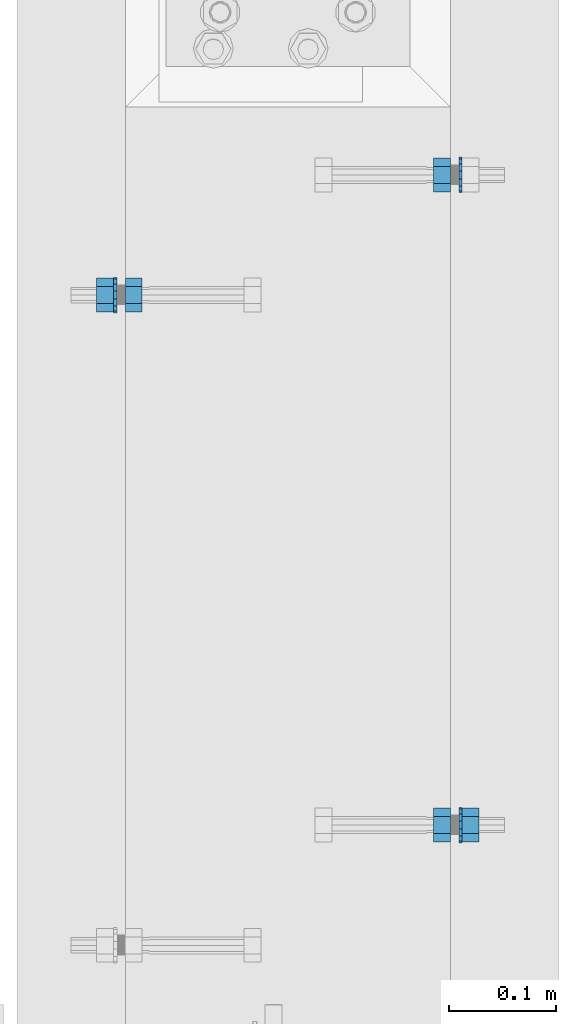
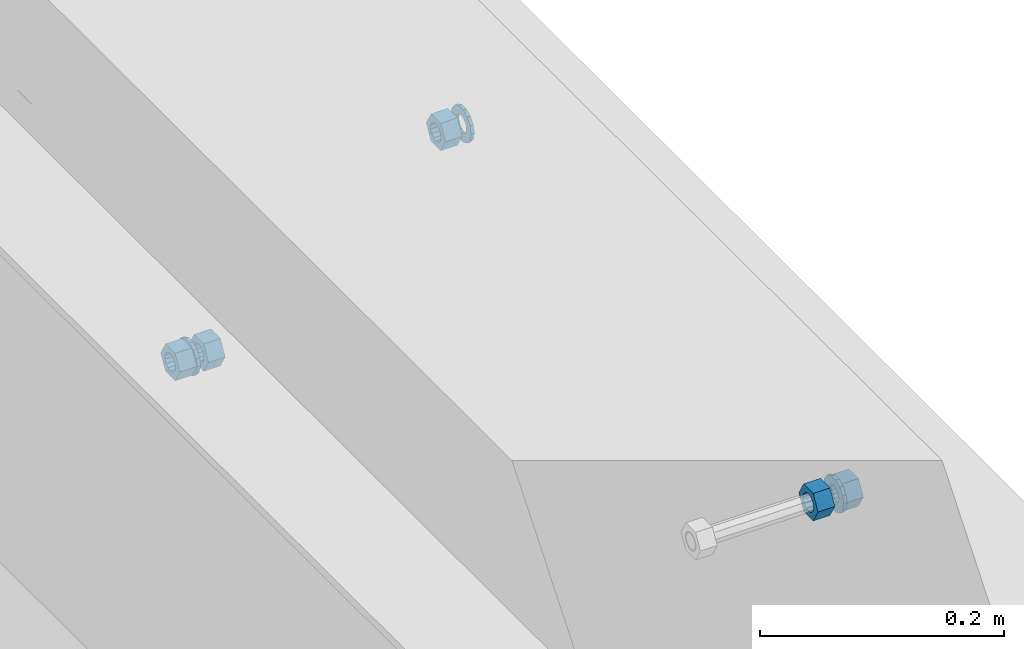
# One storey, part 548 of 975: 8 beams.
"""IFC2X3 building model written with IfcOpenShell, lengths in millimetres."""

from ifc_helpers import new_model, si_unit, frame, origin_with_axes, place, context, subcontext, project, spatial, faceted_brep, material, type_object, element, save


model = new_model("IFC2X3")

# Units and contexts
model_context = context("Model", 3, precision=1e-05, world=origin_with_axes())
body_context = subcontext(model_context, "Body", "Model", "MODEL_VIEW")
ifc_project = project(units=[si_unit("LENGTHUNIT", "METRE", prefix="MILLI"), si_unit("AREAUNIT", "SQUARE_METRE"), si_unit("VOLUMEUNIT", "CUBIC_METRE"), si_unit("MASSUNIT", "GRAM", prefix="KILO"), si_unit("TIMEUNIT", "SECOND"), si_unit("PLANEANGLEUNIT", "RADIAN"), si_unit("SOLIDANGLEUNIT", "STERADIAN"), si_unit("THERMODYNAMICTEMPERATUREUNIT", "DEGREE_CELSIUS"), si_unit("LUMINOUSINTENSITYUNIT", "LUMEN")], contexts=[model_context])

# Site, building, storey
site_placement = place(None, origin_with_axes())
site = spatial("IfcSite", under=ifc_project, at=site_placement, CompositionType="ELEMENT")
building_placement = place(site_placement, origin_with_axes())
building = spatial("IfcBuilding", under=site, at=building_placement, Name="Undefined", CompositionType="ELEMENT")
storey_placement = place(building_placement, origin_with_axes())
storey = spatial("IfcBuildingStorey", under=building, at=storey_placement, Name="Undefined", CompositionType="ELEMENT", Elevation=0.0)

# Beams
ifc_material = material(Name="STEEL/A36")
beam_type_1 = type_object("IfcBeamType", Name="5/8_HEAVY_HEX_NUT", PredefinedType="NOTDEFINED")
beam_1_placement = place(storey_placement, frame((2016.12497640005, 6748.46242676667, 3835.4), z_axis=(0.0, 0.0, 1.0), x_axis=(1.0, 0.0, 0.0)))
element("IfcBeam", 1, at=beam_1_placement, inside=storey, type_object=beam_type_1, material=ifc_material, Name="NUT", ObjectType="5/8_HEAVY_HEX_NUT", context=body_context, shape_type="Brep", body=[
    faceted_brep([(-1.09139364212751e-11, -15.8800001144436, -2.72848410531878e-12), (1.45519152283669e-11, -7.94000005722046, -13.7500000000036), (15.8750000000146, -7.94000005722137, -13.7500000000045), (15.8749999999891, -15.8800001144446, -2.72848410531878e-12), (2.91038304567337e-11, 7.94000005722319, -13.7500000000027), (15.8750000000291, 7.94000005722319, -13.7500000000027), (2.18278728425503e-11, 15.8800001144436, 9.09494701772928e-13), (15.8750000000218, 15.8800001144427, 9.09494701772928e-13), (-7.27595761418343e-12, 7.94000005722046, 13.7500000000027), (15.8749999999927, 7.94000005722046, 13.7500000000027), (-2.18278728425503e-11, -7.94000005722228, 13.7500000000009), (15.8749999999782, -7.94000005722319, 13.7500000000009), (-7.27595761418343e-12, 0.0, 8.72999954223724), (0.0, 3.78780484388062, 7.86545780435881), (15.875, 3.78780484387971, 7.86545780435881), (15.8749999999927, -9.09494701772928e-13, 8.72999954223724), (7.27595761418343e-12, 6.82538848405238, 5.44306568481716), (15.8750000000073, 6.82538848405238, 5.44306568481716), (1.09139364212751e-11, 8.51112022706275, 1.94260765157742), (15.8750000000109, 8.51112022706093, 1.94260765157651), (1.45519152283669e-11, 8.51112022706184, -1.94260765157651), (15.8750000000146, 8.51112022706184, -1.94260765157651), (2.18278728425503e-11, 6.8253884840542, -5.44306568481716), (15.8750000000218, 6.82538848405238, -5.44306568481716), (1.81898940354586e-11, 3.78780484388153, -7.86545780435881), (15.8750000000182, 3.78780484388062, -7.86545780435881), (1.81898940354586e-11, 9.09494701772928e-13, -8.72999954223997), (15.8750000000182, 9.09494701772928e-13, -8.72999954223997), (1.09139364212751e-11, -3.78780484387971, -7.86545780436063), (15.8750000000109, -3.78780484388062, -7.86545780436063), (3.63797880709171e-12, -6.82538848405238, -5.44306568481807), (15.8750000000036, -6.82538848405329, -5.44306568481807), (0.0, -8.51112022706184, -1.94260765157833), (15.875, -8.51112022706184, -1.94260765157833), (-7.27595761418343e-12, -8.51112022706184, 1.9426076515756), (15.8749999999927, -8.51112022706275, 1.9426076515756), (-1.09139364212751e-11, -6.82538848405329, 5.44306568481534), (15.8749999999927, -6.8253884840542, 5.44306568481534), (-7.27595761418343e-12, -3.78780484388062, 7.8654578043579), (15.8749999999927, -3.78780484388153, 7.8654578043579)], [[[0, 1, 2, 3]], [[1, 4, 5, 2]], [[4, 6, 7, 5]], [[6, 8, 9, 7]], [[8, 10, 11, 9]], [[10, 0, 3, 11]], [[12, 13, 14, 15]], [[13, 16, 17, 14]], [[16, 18, 19, 17]], [[18, 20, 21, 19]], [[20, 22, 23, 21]], [[22, 24, 25, 23]], [[24, 26, 27, 25]], [[26, 28, 29, 27]], [[28, 30, 31, 29]], [[30, 32, 33, 31]], [[32, 34, 35, 33]], [[34, 36, 37, 35]], [[36, 38, 39, 37]], [[38, 12, 15, 39]], [[5, 7, 9, 11, 3, 2], [17, 19, 21, 23, 25, 27, 29, 31, 33, 35, 37, 39, 15, 14]], [[10, 8, 6, 4, 1, 0], [38, 36, 34, 32, 30, 28, 26, 24, 22, 20, 18, 16, 13, 12]]]),
])
beam_2_placement = place(storey_placement, frame((2320.92506496676, 6861.17497611239, 3886.2), z_axis=(0.0, 0.0, -1.0), x_axis=(-0.999999999999998, 6.90000001668524e-08, 0.0)))
element("IfcBeam", 2, at=beam_2_placement, inside=storey, type_object=beam_type_1, material=ifc_material, Name="NUT", ObjectType="5/8_HEAVY_HEX_NUT", context=body_context, shape_type="Brep", body=[
    faceted_brep([(-1.09139364212751e-11, -15.8800001144436, -2.72848410531878e-12), (1.45519152283669e-11, -7.94000005722046, -13.7500000000036), (15.8750000000146, -7.94000005722137, -13.7500000000045), (15.8749999999891, -15.8800001144446, -2.72848410531878e-12), (2.91038304567337e-11, 7.94000005722319, -13.7500000000027), (15.8750000000291, 7.94000005722319, -13.7500000000027), (2.18278728425503e-11, 15.8800001144436, 9.09494701772928e-13), (15.8750000000218, 15.8800001144427, 9.09494701772928e-13), (-7.27595761418343e-12, 7.94000005722046, 13.7500000000027), (15.8749999999927, 7.94000005722046, 13.7500000000027), (-2.18278728425503e-11, -7.94000005722228, 13.7500000000009), (15.8749999999782, -7.94000005722319, 13.7500000000009), (-7.27595761418343e-12, 0.0, 8.72999954223724), (0.0, 3.78780484388062, 7.86545780435881), (15.875, 3.78780484387971, 7.86545780435881), (15.8749999999927, -9.09494701772928e-13, 8.72999954223724), (7.27595761418343e-12, 6.82538848405238, 5.44306568481716), (15.8750000000073, 6.82538848405238, 5.44306568481716), (1.09139364212751e-11, 8.51112022706275, 1.94260765157742), (15.8750000000109, 8.51112022706093, 1.94260765157651), (1.45519152283669e-11, 8.51112022706184, -1.94260765157651), (15.8750000000146, 8.51112022706184, -1.94260765157651), (2.18278728425503e-11, 6.8253884840542, -5.44306568481716), (15.8750000000218, 6.82538848405238, -5.44306568481716), (1.81898940354586e-11, 3.78780484388153, -7.86545780435881), (15.8750000000182, 3.78780484388062, -7.86545780435881), (1.81898940354586e-11, 9.09494701772928e-13, -8.72999954223997), (15.8750000000182, 9.09494701772928e-13, -8.72999954223997), (1.09139364212751e-11, -3.78780484387971, -7.86545780436063), (15.8750000000109, -3.78780484388062, -7.86545780436063), (3.63797880709171e-12, -6.82538848405238, -5.44306568481807), (15.8750000000036, -6.82538848405329, -5.44306568481807), (0.0, -8.51112022706184, -1.94260765157833), (15.875, -8.51112022706184, -1.94260765157833), (-7.27595761418343e-12, -8.51112022706184, 1.9426076515756), (15.8749999999927, -8.51112022706275, 1.9426076515756), (-1.09139364212751e-11, -6.82538848405329, 5.44306568481534), (15.8749999999927, -6.8253884840542, 5.44306568481534), (-7.27595761418343e-12, -3.78780484388062, 7.8654578043579), (15.8749999999927, -3.78780484388153, 7.8654578043579)], [[[0, 1, 2, 3]], [[1, 4, 5, 2]], [[4, 6, 7, 5]], [[6, 8, 9, 7]], [[8, 10, 11, 9]], [[10, 0, 3, 11]], [[12, 13, 14, 15]], [[13, 16, 17, 14]], [[16, 18, 19, 17]], [[18, 20, 21, 19]], [[20, 22, 23, 21]], [[22, 24, 25, 23]], [[24, 26, 27, 25]], [[26, 28, 29, 27]], [[28, 30, 31, 29]], [[30, 32, 33, 31]], [[32, 34, 35, 33]], [[34, 36, 37, 35]], [[36, 38, 39, 37]], [[38, 12, 15, 39]], [[5, 7, 9, 11, 3, 2], [17, 19, 21, 23, 25, 27, 29, 31, 33, 35, 37, 39, 15, 14]], [[10, 8, 6, 4, 1, 0], [38, 36, 34, 32, 30, 28, 26, 24, 22, 20, 18, 16, 13, 12]]]),
])
beam_3_placement = place(storey_placement, frame((2320.92502900036, 6251.5749761124, 3886.2), z_axis=(0.0, 0.0, -1.0), x_axis=(-0.999999999999998, 6.90000001668524e-08, 0.0)))
element("IfcBeam", 3, at=beam_3_placement, inside=storey, type_object=beam_type_1, material=ifc_material, Name="NUT", ObjectType="5/8_HEAVY_HEX_NUT", context=body_context, shape_type="Brep", body=[
    faceted_brep([(-1.09139364212751e-11, -15.8800001144436, -2.72848410531878e-12), (1.45519152283669e-11, -7.94000005722046, -13.7500000000036), (15.8750000000146, -7.94000005722137, -13.7500000000045), (15.8749999999891, -15.8800001144446, -2.72848410531878e-12), (2.91038304567337e-11, 7.94000005722319, -13.7500000000027), (15.8750000000291, 7.94000005722319, -13.7500000000027), (2.18278728425503e-11, 15.8800001144436, 9.09494701772928e-13), (15.8750000000218, 15.8800001144427, 9.09494701772928e-13), (-7.27595761418343e-12, 7.94000005722046, 13.7500000000027), (15.8749999999927, 7.94000005722046, 13.7500000000027), (-2.18278728425503e-11, -7.94000005722228, 13.7500000000009), (15.8749999999782, -7.94000005722319, 13.7500000000009), (-7.27595761418343e-12, 0.0, 8.72999954223724), (0.0, 3.78780484388062, 7.86545780435881), (15.875, 3.78780484387971, 7.86545780435881), (15.8749999999927, -9.09494701772928e-13, 8.72999954223724), (7.27595761418343e-12, 6.82538848405238, 5.44306568481716), (15.8750000000073, 6.82538848405238, 5.44306568481716), (1.09139364212751e-11, 8.51112022706275, 1.94260765157742), (15.8750000000109, 8.51112022706093, 1.94260765157651), (1.45519152283669e-11, 8.51112022706184, -1.94260765157651), (15.8750000000146, 8.51112022706184, -1.94260765157651), (2.18278728425503e-11, 6.8253884840542, -5.44306568481716), (15.8750000000218, 6.82538848405238, -5.44306568481716), (1.81898940354586e-11, 3.78780484388153, -7.86545780435881), (15.8750000000182, 3.78780484388062, -7.86545780435881), (1.81898940354586e-11, 9.09494701772928e-13, -8.72999954223997), (15.8750000000182, 9.09494701772928e-13, -8.72999954223997), (1.09139364212751e-11, -3.78780484387971, -7.86545780436063), (15.8750000000109, -3.78780484388062, -7.86545780436063), (3.63797880709171e-12, -6.82538848405238, -5.44306568481807), (15.8750000000036, -6.82538848405329, -5.44306568481807), (0.0, -8.51112022706184, -1.94260765157833), (15.875, -8.51112022706184, -1.94260765157833), (-7.27595761418343e-12, -8.51112022706184, 1.9426076515756), (15.8749999999927, -8.51112022706275, 1.9426076515756), (-1.09139364212751e-11, -6.82538848405329, 5.44306568481534), (15.8749999999927, -6.8253884840542, 5.44306568481534), (-7.27595761418343e-12, -3.78780484388062, 7.8654578043579), (15.8749999999927, -3.78780484388153, 7.8654578043579)], [[[0, 1, 2, 3]], [[1, 4, 5, 2]], [[4, 6, 7, 5]], [[6, 8, 9, 7]], [[8, 10, 11, 9]], [[10, 0, 3, 11]], [[12, 13, 14, 15]], [[13, 16, 17, 14]], [[16, 18, 19, 17]], [[18, 20, 21, 19]], [[20, 22, 23, 21]], [[22, 24, 25, 23]], [[24, 26, 27, 25]], [[26, 28, 29, 27]], [[28, 30, 31, 29]], [[30, 32, 33, 31]], [[32, 34, 35, 33]], [[34, 36, 37, 35]], [[36, 38, 39, 37]], [[38, 12, 15, 39]], [[5, 7, 9, 11, 3, 2], [17, 19, 21, 23, 25, 27, 29, 31, 33, 35, 37, 39, 15, 14]], [[10, 8, 6, 4, 1, 0], [38, 36, 34, 32, 30, 28, 26, 24, 22, 20, 18, 16, 13, 12]]]),
])
beam_4_placement = place(storey_placement, frame((1989.13747520503, 6748.46242695565, 3835.4), z_axis=(0.0, 0.0, 1.0), x_axis=(1.0, 0.0, 0.0)))
element("IfcBeam", 4, at=beam_4_placement, inside=storey, type_object=beam_type_1, material=ifc_material, Name="NUT", ObjectType="5/8_HEAVY_HEX_NUT", context=body_context, shape_type="Brep", body=[
    faceted_brep([(-1.09139364212751e-11, -15.8800001144436, -2.72848410531878e-12), (1.45519152283669e-11, -7.94000005722046, -13.7500000000036), (15.8750000000146, -7.94000005722137, -13.7500000000045), (15.8749999999891, -15.8800001144446, -2.72848410531878e-12), (2.91038304567337e-11, 7.94000005722319, -13.7500000000027), (15.8750000000291, 7.94000005722319, -13.7500000000027), (2.18278728425503e-11, 15.8800001144436, 9.09494701772928e-13), (15.8750000000218, 15.8800001144427, 9.09494701772928e-13), (-7.27595761418343e-12, 7.94000005722046, 13.7500000000027), (15.8749999999927, 7.94000005722046, 13.7500000000027), (-2.18278728425503e-11, -7.94000005722228, 13.7500000000009), (15.8749999999782, -7.94000005722319, 13.7500000000009), (-7.27595761418343e-12, 0.0, 8.72999954223724), (0.0, 3.78780484388062, 7.86545780435881), (15.875, 3.78780484387971, 7.86545780435881), (15.8749999999927, -9.09494701772928e-13, 8.72999954223724), (7.27595761418343e-12, 6.82538848405238, 5.44306568481716), (15.8750000000073, 6.82538848405238, 5.44306568481716), (1.09139364212751e-11, 8.51112022706275, 1.94260765157742), (15.8750000000109, 8.51112022706093, 1.94260765157651), (1.45519152283669e-11, 8.51112022706184, -1.94260765157651), (15.8750000000146, 8.51112022706184, -1.94260765157651), (2.18278728425503e-11, 6.8253884840542, -5.44306568481716), (15.8750000000218, 6.82538848405238, -5.44306568481716), (1.81898940354586e-11, 3.78780484388153, -7.86545780435881), (15.8750000000182, 3.78780484388062, -7.86545780435881), (1.81898940354586e-11, 9.09494701772928e-13, -8.72999954223997), (15.8750000000182, 9.09494701772928e-13, -8.72999954223997), (1.09139364212751e-11, -3.78780484387971, -7.86545780436063), (15.8750000000109, -3.78780484388062, -7.86545780436063), (3.63797880709171e-12, -6.82538848405238, -5.44306568481807), (15.8750000000036, -6.82538848405329, -5.44306568481807), (0.0, -8.51112022706184, -1.94260765157833), (15.875, -8.51112022706184, -1.94260765157833), (-7.27595761418343e-12, -8.51112022706184, 1.9426076515756), (15.8749999999927, -8.51112022706275, 1.9426076515756), (-1.09139364212751e-11, -6.82538848405329, 5.44306568481534), (15.8749999999927, -6.8253884840542, 5.44306568481534), (-7.27595761418343e-12, -3.78780484388062, 7.8654578043579), (15.8749999999927, -3.78780484388153, 7.8654578043579)], [[[0, 1, 2, 3]], [[1, 4, 5, 2]], [[4, 6, 7, 5]], [[6, 8, 9, 7]], [[8, 10, 11, 9]], [[10, 0, 3, 11]], [[12, 13, 14, 15]], [[13, 16, 17, 14]], [[16, 18, 19, 17]], [[18, 20, 21, 19]], [[20, 22, 23, 21]], [[22, 24, 25, 23]], [[24, 26, 27, 25]], [[26, 28, 29, 27]], [[28, 30, 31, 29]], [[30, 32, 33, 31]], [[32, 34, 35, 33]], [[34, 36, 37, 35]], [[36, 38, 39, 37]], [[38, 12, 15, 39]], [[5, 7, 9, 11, 3, 2], [17, 19, 21, 23, 25, 27, 29, 31, 33, 35, 37, 39, 15, 14]], [[10, 8, 6, 4, 1, 0], [38, 36, 34, 32, 30, 28, 26, 24, 22, 20, 18, 16, 13, 12]]]),
])
beam_5_placement = place(storey_placement, frame((2347.91252900035, 6251.5749761124, 3886.2), z_axis=(0.0, 0.0, -1.0), x_axis=(-0.999999999999998, 6.90000001668524e-08, 0.0)))
element("IfcBeam", 5, at=beam_5_placement, inside=storey, type_object=beam_type_1, material=ifc_material, Name="NUT", ObjectType="5/8_HEAVY_HEX_NUT", context=body_context, shape_type="Brep", body=[
    faceted_brep([(-1.09139364212751e-11, -15.8800001144436, -2.72848410531878e-12), (1.45519152283669e-11, -7.94000005722046, -13.7500000000036), (15.8750000000146, -7.94000005722137, -13.7500000000045), (15.8749999999891, -15.8800001144446, -2.72848410531878e-12), (2.91038304567337e-11, 7.94000005722319, -13.7500000000027), (15.8750000000291, 7.94000005722319, -13.7500000000027), (2.18278728425503e-11, 15.8800001144436, 9.09494701772928e-13), (15.8750000000218, 15.8800001144427, 9.09494701772928e-13), (-7.27595761418343e-12, 7.94000005722046, 13.7500000000027), (15.8749999999927, 7.94000005722046, 13.7500000000027), (-2.18278728425503e-11, -7.94000005722228, 13.7500000000009), (15.8749999999782, -7.94000005722319, 13.7500000000009), (-7.27595761418343e-12, 0.0, 8.72999954223724), (0.0, 3.78780484388062, 7.86545780435881), (15.875, 3.78780484387971, 7.86545780435881), (15.8749999999927, -9.09494701772928e-13, 8.72999954223724), (7.27595761418343e-12, 6.82538848405238, 5.44306568481716), (15.8750000000073, 6.82538848405238, 5.44306568481716), (1.09139364212751e-11, 8.51112022706275, 1.94260765157742), (15.8750000000109, 8.51112022706093, 1.94260765157651), (1.45519152283669e-11, 8.51112022706184, -1.94260765157651), (15.8750000000146, 8.51112022706184, -1.94260765157651), (2.18278728425503e-11, 6.8253884840542, -5.44306568481716), (15.8750000000218, 6.82538848405238, -5.44306568481716), (1.81898940354586e-11, 3.78780484388153, -7.86545780435881), (15.8750000000182, 3.78780484388062, -7.86545780435881), (1.81898940354586e-11, 9.09494701772928e-13, -8.72999954223997), (15.8750000000182, 9.09494701772928e-13, -8.72999954223997), (1.09139364212751e-11, -3.78780484387971, -7.86545780436063), (15.8750000000109, -3.78780484388062, -7.86545780436063), (3.63797880709171e-12, -6.82538848405238, -5.44306568481807), (15.8750000000036, -6.82538848405329, -5.44306568481807), (0.0, -8.51112022706184, -1.94260765157833), (15.875, -8.51112022706184, -1.94260765157833), (-7.27595761418343e-12, -8.51112022706184, 1.9426076515756), (15.8749999999927, -8.51112022706275, 1.9426076515756), (-1.09139364212751e-11, -6.82538848405329, 5.44306568481534), (15.8749999999927, -6.8253884840542, 5.44306568481534), (-7.27595761418343e-12, -3.78780484388062, 7.8654578043579), (15.8749999999927, -3.78780484388153, 7.8654578043579)], [[[0, 1, 2, 3]], [[1, 4, 5, 2]], [[4, 6, 7, 5]], [[6, 8, 9, 7]], [[8, 10, 11, 9]], [[10, 0, 3, 11]], [[12, 13, 14, 15]], [[13, 16, 17, 14]], [[16, 18, 19, 17]], [[18, 20, 21, 19]], [[20, 22, 23, 21]], [[22, 24, 25, 23]], [[24, 26, 27, 25]], [[26, 28, 29, 27]], [[28, 30, 31, 29]], [[30, 32, 33, 31]], [[32, 34, 35, 33]], [[34, 36, 37, 35]], [[36, 38, 39, 37]], [[38, 12, 15, 39]], [[5, 7, 9, 11, 3, 2], [17, 19, 21, 23, 25, 27, 29, 31, 33, 35, 37, 39, 15, 14]], [[10, 8, 6, 4, 1, 0], [38, 36, 34, 32, 30, 28, 26, 24, 22, 20, 18, 16, 13, 12]]]),
])
beam_type_2 = type_object("IfcBeamType", Name="5/8_WASHER", PredefinedType="NOTDEFINED")
beam_6_placement = place(storey_placement, frame((2005.01247520503, 6748.46242684456, 3835.4), z_axis=(0.0, 0.0, 1.0), x_axis=(1.0, 0.0, 0.0)))
element("IfcBeam", 6, at=beam_6_placement, inside=storey, type_object=beam_type_2, material=ifc_material, Name="WASHER", ObjectType="5/8_WASHER", context=body_context, shape_type="Brep", body=[
    faceted_brep([(1.09139364212751e-11, -16.670000076293, -2.72848410531878e-12), (2.18278728425503e-11, -15.0191510966704, -7.23284196419536), (3.1750000000211, -15.0191510966711, -7.23284196419627), (3.17500000001019, -16.6700000762937, -1.81898940354586e-12), (2.91038304567337e-11, -10.3935750445523, -13.0331308723944), (3.17500000002838, -10.3935750445526, -13.0331308723953), (2.91038304567337e-11, -3.70942398602756, -16.2520483704566), (3.17500000002838, -3.70942398602779, -16.2520483704566), (2.5465851649642e-11, 3.70942398602961, -16.2520483704557), (3.17500000002474, 3.70942398602961, -16.2520483704566), (1.45519152283669e-11, 10.3935750445542, -13.0331308723935), (3.17500000001382, 10.3935750445537, -13.0331308723944), (0.0, 15.0191510966717, -7.23284196419354), (3.17499999999927, 15.0191510966713, -7.23284196419354), (-7.27595761418343e-12, 16.6700000762933, 0.0), (3.174999999992, 16.6700000762928, -9.09494701772928e-13), (-1.81898940354586e-11, 15.0191510966706, 7.23284196419354), (3.17499999998108, 15.0191510966704, 7.23284196419354), (-2.5465851649642e-11, 10.3935750445519, 13.0331308723926), (3.17499999997381, 10.3935750445517, 13.0331308723926), (-2.5465851649642e-11, 3.70942398602733, 16.2520483704538), (3.17499999997381, 3.7094239860271, 16.2520483704529), (-2.18278728425503e-11, -3.70942398602983, 16.2520483704529), (3.17499999997744, -3.70942398603006, 16.2520483704538), (-1.09139364212751e-11, -10.3935750445542, 13.0331308723908), (3.17499999998836, -10.3935750445544, 13.0331308723908), (0.0, -15.0191510966717, 7.23284196419172), (3.17499999999927, -15.019151096672, 7.23284196419081), (-7.27595761418343e-12, 0.0, 8.72999954223724), (0.0, 3.78780484388062, 7.86545780435881), (3.17499999998472, 3.78780484387903, 7.86545780435699), (3.17499999998836, -9.09494701772928e-13, 8.72999954223542), (7.27595761418343e-12, 6.82538848405238, 5.44306568481716), (3.17499999998836, 6.82538848405102, 5.44306568481534), (1.09139364212751e-11, 8.51112022706275, 1.94260765157742), (3.174999999992, 8.51112022705979, 1.94260765157651), (1.45519152283669e-11, 8.51112022706184, -1.94260765157651), (3.17499999999563, 8.51112022706025, -1.94260765157742), (2.18278728425503e-11, 6.8253884840542, -5.44306568481716), (3.17500000000655, 6.8253884840517, -5.44306568481807), (1.81898940354586e-11, 3.78780484388153, -7.86545780435881), (3.17500000001019, 3.78780484388017, -7.86545780435972), (1.81898940354586e-11, 9.09494701772928e-13, -8.72999954223997), (3.17500000001382, 6.82121026329696e-13, -8.72999954223997), (1.09139364212751e-11, -3.78780484387971, -7.86545780436063), (3.17500000001382, -3.78780484387994, -7.86545780436063), (3.63797880709171e-12, -6.82538848405238, -5.44306568481807), (3.17500000001019, -6.82538848405147, -5.44306568481898), (0.0, -8.51112022706184, -1.94260765157833), (3.17500000001019, -8.5111202270607, -1.94260765157924), (-7.27595761418343e-12, -8.51112022706184, 1.9426076515756), (3.17500000000291, -8.51112022706093, 1.94260765157469), (-1.09139364212751e-11, -6.82538848405329, 5.44306568481534), (3.17499999999563, -6.82538848405238, 5.44306568481534), (-7.27595761418343e-12, -3.78780484388062, 7.8654578043579), (3.174999999992, -3.78780484388085, 7.86545780435699)], [[[0, 1, 2, 3]], [[1, 4, 5, 2]], [[4, 6, 7, 5]], [[6, 8, 9, 7]], [[8, 10, 11, 9]], [[10, 12, 13, 11]], [[12, 14, 15, 13]], [[14, 16, 17, 15]], [[16, 18, 19, 17]], [[18, 20, 21, 19]], [[20, 22, 23, 21]], [[22, 24, 25, 23]], [[24, 26, 27, 25]], [[26, 0, 3, 27]], [[28, 29, 30, 31]], [[29, 32, 33, 30]], [[32, 34, 35, 33]], [[34, 36, 37, 35]], [[36, 38, 39, 37]], [[38, 40, 41, 39]], [[40, 42, 43, 41]], [[42, 44, 45, 43]], [[44, 46, 47, 45]], [[46, 48, 49, 47]], [[48, 50, 51, 49]], [[50, 52, 53, 51]], [[52, 54, 55, 53]], [[54, 28, 31, 55]], [[5, 7, 9, 11, 13, 15, 17, 19, 21, 23, 25, 27, 3, 2], [33, 35, 37, 39, 41, 43, 45, 47, 49, 51, 53, 55, 31, 30]], [[26, 24, 22, 20, 18, 16, 14, 12, 10, 8, 6, 4, 1, 0], [54, 52, 50, 48, 46, 44, 42, 40, 38, 36, 34, 32, 29, 28]]]),
])
beam_7_placement = place(storey_placement, frame((2332.03752900035, 6251.5749761124, 3886.2), z_axis=(0.0, 0.0, -1.0), x_axis=(-0.999999999999998, 6.90000001668524e-08, 0.0)))
element("IfcBeam", 7, at=beam_7_placement, inside=storey, type_object=beam_type_2, material=ifc_material, Name="WASHER", ObjectType="5/8_WASHER", context=body_context, shape_type="Brep", body=[
    faceted_brep([(1.09139364212751e-11, -16.670000076293, -2.72848410531878e-12), (2.18278728425503e-11, -15.0191510966704, -7.23284196419536), (3.1750000000211, -15.0191510966711, -7.23284196419627), (3.17500000001019, -16.6700000762937, -1.81898940354586e-12), (2.91038304567337e-11, -10.3935750445523, -13.0331308723944), (3.17500000002838, -10.3935750445526, -13.0331308723953), (2.91038304567337e-11, -3.70942398602756, -16.2520483704566), (3.17500000002838, -3.70942398602779, -16.2520483704566), (2.5465851649642e-11, 3.70942398602961, -16.2520483704557), (3.17500000002474, 3.70942398602961, -16.2520483704566), (1.45519152283669e-11, 10.3935750445542, -13.0331308723935), (3.17500000001382, 10.3935750445537, -13.0331308723944), (0.0, 15.0191510966717, -7.23284196419354), (3.17499999999927, 15.0191510966713, -7.23284196419354), (-7.27595761418343e-12, 16.6700000762933, 0.0), (3.174999999992, 16.6700000762928, -9.09494701772928e-13), (-1.81898940354586e-11, 15.0191510966706, 7.23284196419354), (3.17499999998108, 15.0191510966704, 7.23284196419354), (-2.5465851649642e-11, 10.3935750445519, 13.0331308723926), (3.17499999997381, 10.3935750445517, 13.0331308723926), (-2.5465851649642e-11, 3.70942398602733, 16.2520483704538), (3.17499999997381, 3.7094239860271, 16.2520483704529), (-2.18278728425503e-11, -3.70942398602983, 16.2520483704529), (3.17499999997744, -3.70942398603006, 16.2520483704538), (-1.09139364212751e-11, -10.3935750445542, 13.0331308723908), (3.17499999998836, -10.3935750445544, 13.0331308723908), (0.0, -15.0191510966717, 7.23284196419172), (3.17499999999927, -15.019151096672, 7.23284196419081), (-7.27595761418343e-12, 0.0, 8.72999954223724), (0.0, 3.78780484388062, 7.86545780435881), (3.17499999998472, 3.78780484387903, 7.86545780435699), (3.17499999998836, -9.09494701772928e-13, 8.72999954223542), (7.27595761418343e-12, 6.82538848405238, 5.44306568481716), (3.17499999998836, 6.82538848405102, 5.44306568481534), (1.09139364212751e-11, 8.51112022706275, 1.94260765157742), (3.174999999992, 8.51112022705979, 1.94260765157651), (1.45519152283669e-11, 8.51112022706184, -1.94260765157651), (3.17499999999563, 8.51112022706025, -1.94260765157742), (2.18278728425503e-11, 6.8253884840542, -5.44306568481716), (3.17500000000655, 6.8253884840517, -5.44306568481807), (1.81898940354586e-11, 3.78780484388153, -7.86545780435881), (3.17500000001019, 3.78780484388017, -7.86545780435972), (1.81898940354586e-11, 9.09494701772928e-13, -8.72999954223997), (3.17500000001382, 6.82121026329696e-13, -8.72999954223997), (1.09139364212751e-11, -3.78780484387971, -7.86545780436063), (3.17500000001382, -3.78780484387994, -7.86545780436063), (3.63797880709171e-12, -6.82538848405238, -5.44306568481807), (3.17500000001019, -6.82538848405147, -5.44306568481898), (0.0, -8.51112022706184, -1.94260765157833), (3.17500000001019, -8.5111202270607, -1.94260765157924), (-7.27595761418343e-12, -8.51112022706184, 1.9426076515756), (3.17500000000291, -8.51112022706093, 1.94260765157469), (-1.09139364212751e-11, -6.82538848405329, 5.44306568481534), (3.17499999999563, -6.82538848405238, 5.44306568481534), (-7.27595761418343e-12, -3.78780484388062, 7.8654578043579), (3.174999999992, -3.78780484388085, 7.86545780435699)], [[[0, 1, 2, 3]], [[1, 4, 5, 2]], [[4, 6, 7, 5]], [[6, 8, 9, 7]], [[8, 10, 11, 9]], [[10, 12, 13, 11]], [[12, 14, 15, 13]], [[14, 16, 17, 15]], [[16, 18, 19, 17]], [[18, 20, 21, 19]], [[20, 22, 23, 21]], [[22, 24, 25, 23]], [[24, 26, 27, 25]], [[26, 0, 3, 27]], [[28, 29, 30, 31]], [[29, 32, 33, 30]], [[32, 34, 35, 33]], [[34, 36, 37, 35]], [[36, 38, 39, 37]], [[38, 40, 41, 39]], [[40, 42, 43, 41]], [[42, 44, 45, 43]], [[44, 46, 47, 45]], [[46, 48, 49, 47]], [[48, 50, 51, 49]], [[50, 52, 53, 51]], [[52, 54, 55, 53]], [[54, 28, 31, 55]], [[5, 7, 9, 11, 13, 15, 17, 19, 21, 23, 25, 27, 3, 2], [33, 35, 37, 39, 41, 43, 45, 47, 49, 51, 53, 55, 31, 30]], [[26, 24, 22, 20, 18, 16, 14, 12, 10, 8, 6, 4, 1, 0], [54, 52, 50, 48, 46, 44, 42, 40, 38, 36, 34, 32, 29, 28]]]),
])
beam_8_placement = place(storey_placement, frame((2332.03756496675, 6861.17497611239, 3886.2), z_axis=(0.0, 0.0, -1.0), x_axis=(-0.999999999999998, 6.90000001668524e-08, 0.0)))
element("IfcBeam", 8, at=beam_8_placement, inside=storey, type_object=beam_type_2, material=ifc_material, Name="WASHER", ObjectType="5/8_WASHER", context=body_context, shape_type="Brep", body=[
    faceted_brep([(1.09139364212751e-11, -16.670000076293, -2.72848410531878e-12), (2.18278728425503e-11, -15.0191510966704, -7.23284196419536), (3.1750000000211, -15.0191510966711, -7.23284196419627), (3.17500000001019, -16.6700000762937, -1.81898940354586e-12), (2.91038304567337e-11, -10.3935750445523, -13.0331308723944), (3.17500000002838, -10.3935750445526, -13.0331308723953), (2.91038304567337e-11, -3.70942398602756, -16.2520483704566), (3.17500000002838, -3.70942398602779, -16.2520483704566), (2.5465851649642e-11, 3.70942398602961, -16.2520483704557), (3.17500000002474, 3.70942398602961, -16.2520483704566), (1.45519152283669e-11, 10.3935750445542, -13.0331308723935), (3.17500000001382, 10.3935750445537, -13.0331308723944), (0.0, 15.0191510966717, -7.23284196419354), (3.17499999999927, 15.0191510966713, -7.23284196419354), (-7.27595761418343e-12, 16.6700000762933, 0.0), (3.174999999992, 16.6700000762928, -9.09494701772928e-13), (-1.81898940354586e-11, 15.0191510966706, 7.23284196419354), (3.17499999998108, 15.0191510966704, 7.23284196419354), (-2.5465851649642e-11, 10.3935750445519, 13.0331308723926), (3.17499999997381, 10.3935750445517, 13.0331308723926), (-2.5465851649642e-11, 3.70942398602733, 16.2520483704538), (3.17499999997381, 3.7094239860271, 16.2520483704529), (-2.18278728425503e-11, -3.70942398602983, 16.2520483704529), (3.17499999997744, -3.70942398603006, 16.2520483704538), (-1.09139364212751e-11, -10.3935750445542, 13.0331308723908), (3.17499999998836, -10.3935750445544, 13.0331308723908), (0.0, -15.0191510966717, 7.23284196419172), (3.17499999999927, -15.019151096672, 7.23284196419081), (-7.27595761418343e-12, 0.0, 8.72999954223724), (0.0, 3.78780484388062, 7.86545780435881), (3.17499999998472, 3.78780484387903, 7.86545780435699), (3.17499999998836, -9.09494701772928e-13, 8.72999954223542), (7.27595761418343e-12, 6.82538848405238, 5.44306568481716), (3.17499999998836, 6.82538848405102, 5.44306568481534), (1.09139364212751e-11, 8.51112022706275, 1.94260765157742), (3.174999999992, 8.51112022705979, 1.94260765157651), (1.45519152283669e-11, 8.51112022706184, -1.94260765157651), (3.17499999999563, 8.51112022706025, -1.94260765157742), (2.18278728425503e-11, 6.8253884840542, -5.44306568481716), (3.17500000000655, 6.8253884840517, -5.44306568481807), (1.81898940354586e-11, 3.78780484388153, -7.86545780435881), (3.17500000001019, 3.78780484388017, -7.86545780435972), (1.81898940354586e-11, 9.09494701772928e-13, -8.72999954223997), (3.17500000001382, 6.82121026329696e-13, -8.72999954223997), (1.09139364212751e-11, -3.78780484387971, -7.86545780436063), (3.17500000001382, -3.78780484387994, -7.86545780436063), (3.63797880709171e-12, -6.82538848405238, -5.44306568481807), (3.17500000001019, -6.82538848405147, -5.44306568481898), (0.0, -8.51112022706184, -1.94260765157833), (3.17500000001019, -8.5111202270607, -1.94260765157924), (-7.27595761418343e-12, -8.51112022706184, 1.9426076515756), (3.17500000000291, -8.51112022706093, 1.94260765157469), (-1.09139364212751e-11, -6.82538848405329, 5.44306568481534), (3.17499999999563, -6.82538848405238, 5.44306568481534), (-7.27595761418343e-12, -3.78780484388062, 7.8654578043579), (3.174999999992, -3.78780484388085, 7.86545780435699)], [[[0, 1, 2, 3]], [[1, 4, 5, 2]], [[4, 6, 7, 5]], [[6, 8, 9, 7]], [[8, 10, 11, 9]], [[10, 12, 13, 11]], [[12, 14, 15, 13]], [[14, 16, 17, 15]], [[16, 18, 19, 17]], [[18, 20, 21, 19]], [[20, 22, 23, 21]], [[22, 24, 25, 23]], [[24, 26, 27, 25]], [[26, 0, 3, 27]], [[28, 29, 30, 31]], [[29, 32, 33, 30]], [[32, 34, 35, 33]], [[34, 36, 37, 35]], [[36, 38, 39, 37]], [[38, 40, 41, 39]], [[40, 42, 43, 41]], [[42, 44, 45, 43]], [[44, 46, 47, 45]], [[46, 48, 49, 47]], [[48, 50, 51, 49]], [[50, 52, 53, 51]], [[52, 54, 55, 53]], [[54, 28, 31, 55]], [[5, 7, 9, 11, 13, 15, 17, 19, 21, 23, 25, 27, 3, 2], [33, 35, 37, 39, 41, 43, 45, 47, 49, 51, 53, 55, 31, 30]], [[26, 24, 22, 20, 18, 16, 14, 12, 10, 8, 6, 4, 1, 0], [54, 52, 50, 48, 46, 44, 42, 40, 38, 36, 34, 32, 29, 28]]]),
])

save(model, "model.ifc")
